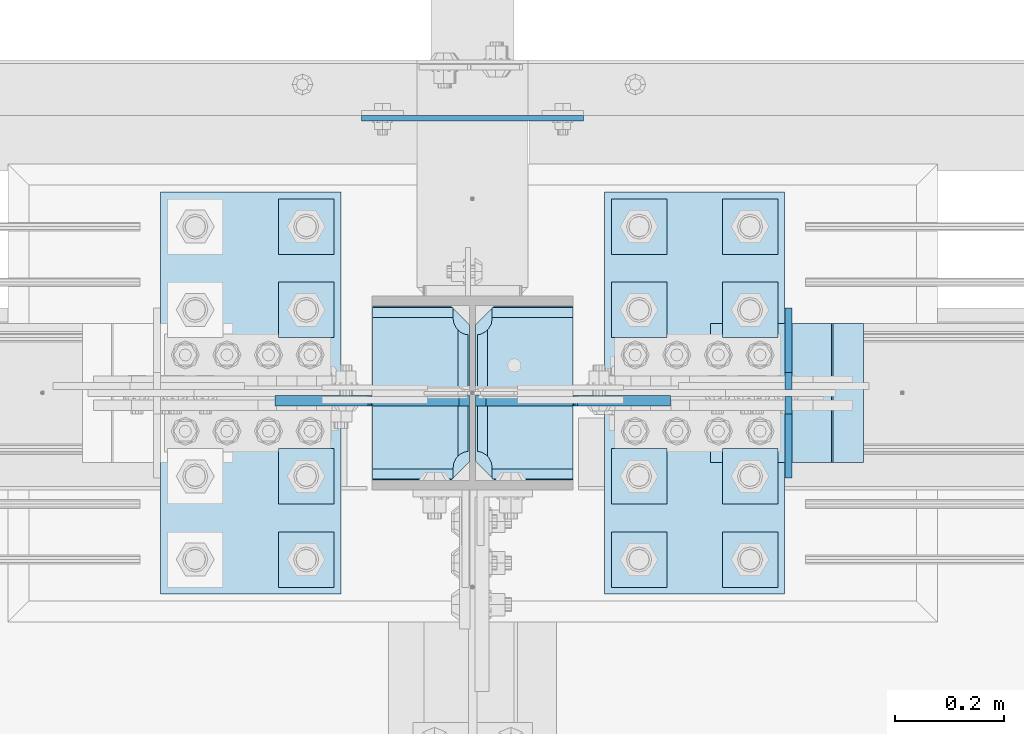
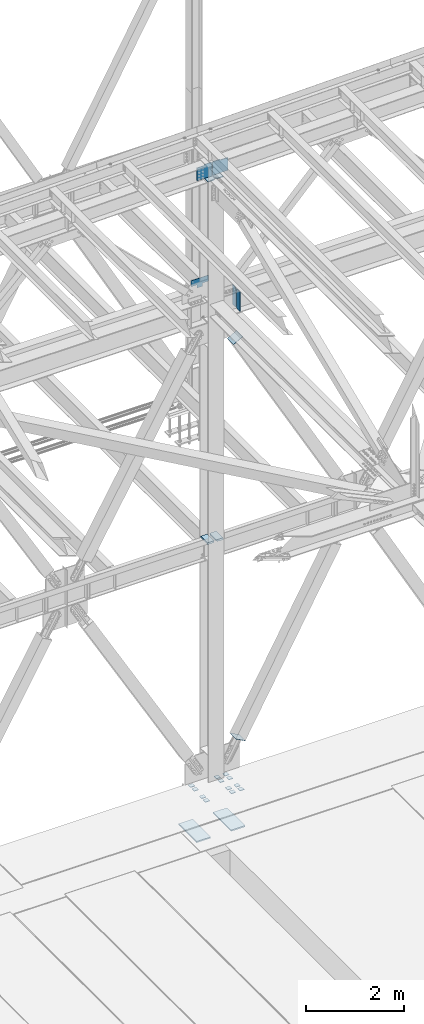
# One storey, part 3478 of 3843: 25 plates, 5 elements without a shape of their own.
"""IFC2X3 building model written with IfcOpenShell, lengths in millimetres."""

from ifc_helpers import new_model, si_unit, frame, origin_with_axes, place, context, subcontext, project, spatial, faceted_brep, material, type_object, element, aggregate, save


model = new_model("IFC2X3")

# Units and contexts
model_context = context("Model", 3, precision=1e-05, world=origin_with_axes())
body_context = subcontext(model_context, "Body", "Model", "MODEL_VIEW")
ifc_project = project(units=[si_unit("LENGTHUNIT", "METRE", prefix="MILLI"), si_unit("AREAUNIT", "SQUARE_METRE"), si_unit("VOLUMEUNIT", "CUBIC_METRE"), si_unit("MASSUNIT", "GRAM", prefix="KILO"), si_unit("TIMEUNIT", "SECOND"), si_unit("PLANEANGLEUNIT", "RADIAN"), si_unit("SOLIDANGLEUNIT", "STERADIAN"), si_unit("THERMODYNAMICTEMPERATUREUNIT", "DEGREE_CELSIUS"), si_unit("LUMINOUSINTENSITYUNIT", "LUMEN")], contexts=[model_context])

# Site, building, storey
site_placement = place(None, origin_with_axes())
site = spatial("IfcSite", under=ifc_project, at=site_placement, CompositionType="ELEMENT")
building_placement = place(site_placement, origin_with_axes())
building = spatial("IfcBuilding", under=site, at=building_placement, Name="Undefined", CompositionType="ELEMENT")
storey_placement = place(building_placement, origin_with_axes())
storey = spatial("IfcBuildingStorey", under=building, at=storey_placement, Name="Undefined", CompositionType="ELEMENT", Elevation=0.0)

# Assembly, plates
assembly_1_placement = place(storey_placement, origin_with_axes())
assembly_1 = element("IfcElementAssembly", 1, at=assembly_1_placement, inside=storey, Name="COLUMN", AssemblyPlace="NOTDEFINED", PredefinedType="RIGID_FRAME")
ifc_material_1 = material(Name="STEEL/A572-50")
plate_type_1 = type_object("IfcPlateType", PredefinedType="NOTDEFINED")
plate_1_placement = place(assembly_1_placement, frame((56114.15625, 92054.3625, 36420.425), z_axis=(0.0, 1.0, 0.0), x_axis=(-1.0, 0.0, 0.0)))
plate_1 = element("IfcPlate", 2, at=plate_1_placement, type_object=plate_type_1, material=ifc_material_1, Name="PLATE", context=body_context, shape_type="Brep", body=[
    faceted_brep([(160.070927103505, 9.33329077896633, 48.2144734940957), (156.294129000915, 15.875, 44.437675391513), (156.294129000915, 15.875, 276.23732460849), (160.070927103505, 9.33329077896633, 272.460526505907), (168.479274789282, -5.23062396988826, 268.176259371801), (174.625000047687, -15.875, 267.202872116366), (174.625000047687, -15.875, 53.4721278836369), (168.479274789282, -5.23062396988826, 52.4987406282016), (147.63749961853, 15.875, 21.5053709990898), (147.63749961853, -15.875, 3.17449995232164), (0.0, -15.875, 3.17449995232164), (0.0, 15.875, 21.5053709990898), (0.0, 15.875, 299.168629000924), (0.0, -15.875, 317.499500047692), (147.63749961853, -15.875, 317.499500047692), (147.63749961853, 15.875, 299.168629000924), (147.63749961853, -15.875, 296.862501907352), (147.63749961853, 15.875, 296.862501907352), (149.113757464445, -15.875, 287.541776696642), (149.113757464445, 15.875, 287.541776696642), (153.398024598548, -15.875, 279.133429010864), (153.398024598548, 15.875, 279.133429010864), (160.070927103505, -15.875, 272.460526505907), (168.479274789282, -15.875, 268.176259371801), (168.479274789282, -15.875, 52.4987406282016), (160.070927103505, -15.875, 48.2144734940957), (153.398024598548, -15.875, 41.5415709891386), (153.398024598548, 15.875, 41.5415709891386), (149.113757464449, -15.875, 33.1332233033609), (149.113757464449, 15.875, 33.1332233033609), (147.63749961853, -15.875, 23.8124980926514), (147.63749961853, 15.875, 23.8124980926514)], [[[0, 1, 2, 3, 4, 5, 6, 7]], [[8, 9, 10, 11]], [[12, 13, 14, 15]], [[13, 12, 11, 10]], [[16, 17, 15, 14]], [[16, 18, 19, 17]], [[18, 20, 21, 19]], [[21, 20, 22, 3, 2]], [[22, 23, 4, 3]], [[23, 5, 4]], [[24, 7, 6]], [[24, 25, 0, 7]], [[25, 26, 27, 1, 0]], [[26, 28, 29, 27]], [[28, 30, 31, 29]], [[31, 30, 9, 8]], [[27, 29, 31, 8, 11, 12, 15, 17, 19, 21, 2, 1]], [[9, 30, 28, 26, 25, 24, 6, 5, 23, 22, 20, 18, 16, 14, 13, 10]]]),
])
plate_2_placement = place(assembly_1_placement, frame((55747.44375, 92375.0375, 36420.425), z_axis=(0.0, -1.0, 0.0), x_axis=(1.0, 0.0, 0.0)))
plate_2 = element("IfcPlate", 3, at=plate_2_placement, type_object=plate_type_1, material=ifc_material_1, Name="PLATE", context=body_context, shape_type="Brep", body=[
    faceted_brep([(160.070927103505, 9.33329077896633, 48.2144734940957), (156.294129000915, 15.875, 44.437675391513), (156.294129000915, 15.875, 276.23732460849), (160.070927103505, 9.33329077896633, 272.460526505907), (168.479274789282, -5.23062396988826, 268.176259371801), (174.625000047687, -15.875, 267.202872116366), (174.625000047687, -15.875, 53.4721278836369), (168.479274789282, -5.23062396988826, 52.4987406282016), (147.63749961853, 15.875, 21.5053709990898), (147.63749961853, -15.875, 3.17449995232164), (0.0, -15.875, 3.17449995232164), (0.0, 15.875, 21.5053709990898), (0.0, 15.875, 299.168629000924), (0.0, -15.875, 317.499500047692), (147.63749961853, -15.875, 317.499500047692), (147.63749961853, 15.875, 299.168629000924), (147.63749961853, -15.875, 296.862501907352), (147.63749961853, 15.875, 296.862501907352), (149.113757464445, -15.875, 287.541776696642), (149.113757464445, 15.875, 287.541776696642), (153.398024598548, -15.875, 279.133429010864), (153.398024598548, 15.875, 279.133429010864), (160.070927103505, -15.875, 272.460526505907), (168.479274789282, -15.875, 268.176259371801), (168.479274789282, -15.875, 52.4987406282016), (160.070927103505, -15.875, 48.2144734940957), (153.398024598548, -15.875, 41.5415709891386), (153.398024598548, 15.875, 41.5415709891386), (149.113757464449, -15.875, 33.1332233033609), (149.113757464449, 15.875, 33.1332233033609), (147.63749961853, -15.875, 23.8124980926514), (147.63749961853, 15.875, 23.8124980926514)], [[[0, 1, 2, 3, 4, 5, 6, 7]], [[8, 9, 10, 11]], [[12, 13, 14, 15]], [[13, 12, 11, 10]], [[16, 17, 15, 14]], [[16, 18, 19, 17]], [[18, 20, 21, 19]], [[21, 20, 22, 3, 2]], [[22, 23, 4, 3]], [[23, 5, 4]], [[24, 7, 6]], [[24, 25, 0, 7]], [[25, 26, 27, 1, 0]], [[26, 28, 29, 27]], [[28, 30, 31, 29]], [[31, 30, 9, 8]], [[27, 29, 31, 8, 11, 12, 15, 17, 19, 21, 2, 1]], [[9, 30, 28, 26, 25, 24, 6, 5, 23, 22, 20, 18, 16, 14, 13, 10]]]),
])
plate_type_2 = type_object("IfcPlateType", PredefinedType="NOTDEFINED")
plate_3_placement = place(assembly_1_placement, frame((56114.15625, 92055.95, 45462.0453960539), z_axis=(0.0, 1.0, 0.0), x_axis=(-1.0, 0.0, 0.0)))
plate_3 = element("IfcPlate", 4, at=plate_3_placement, type_object=plate_type_2, material=ifc_material_1, Name="PLATE", context=body_context, shape_type="Brep", body=[
    faceted_brep([(0.0, -9.52500000000146, 0.0), (0.0, -9.52500000000146, 317.5), (0.0, 9.52500000000146, 317.5), (0.0, 9.52500000000146, 0.0), (144.462501525879, -9.52500000000146, 317.5), (144.462501525879, 9.52500000000146, 317.5), (177.800003051758, -9.52500000000146, 284.162498474121), (177.800003051758, 9.52500000000146, 284.162498474121), (177.800003051758, -9.52500000000146, 33.3375015258789), (177.800003051758, 9.52500000000146, 33.3375015258789), (144.462501525879, -9.52500000000146, 0.0), (144.462501525879, 9.52500000000146, 0.0)], [[[0, 1, 2, 3]], [[1, 4, 5, 2]], [[4, 6, 7, 5]], [[6, 8, 9, 7]], [[8, 10, 11, 9]], [[10, 0, 3, 11]], [[5, 7, 9, 11, 3, 2]], [[10, 8, 6, 4, 1, 0]]]),
])
plate_4_placement = place(assembly_1_placement, frame((55747.4437499977, 92373.45, 45450.540948498), z_axis=(0.0, -1.0, 0.0), x_axis=(1.0, 0.0, 0.0)))
plate_4 = element("IfcPlate", 5, at=plate_4_placement, type_object=plate_type_2, material=ifc_material_1, Name="PLATE", context=body_context, shape_type="Brep", body=[
    faceted_brep([(0.0, -9.52500000000146, 0.0), (0.0, -9.52500000000146, 317.5), (0.0, 9.52500000000146, 317.5), (0.0, 9.52500000000146, 0.0), (144.462501525879, -9.52500000000146, 317.5), (144.462501525879, 9.52500000000146, 317.5), (177.800003051758, -9.52500000000146, 284.162498474121), (177.800003051758, 9.52500000000146, 284.162498474121), (177.800003051758, -9.52500000000146, 33.3375015258789), (177.800003051758, 9.52500000000146, 33.3375015258789), (144.462501525879, -9.52500000000146, 0.0), (144.462501525879, 9.52500000000146, 0.0)], [[[0, 1, 2, 3]], [[1, 4, 5, 2]], [[4, 6, 7, 5]], [[6, 8, 9, 7]], [[8, 10, 11, 9]], [[10, 0, 3, 11]], [[5, 7, 9, 11, 3, 2]], [[10, 8, 6, 4, 1, 0]]]),
])
plate_type_3 = type_object("IfcPlateType", PredefinedType="NOTDEFINED")
plate_5_placement = place(assembly_1_placement, frame((55867.3, 92717.9375, 42367.2), z_axis=(0.0, 0.0, 1.0), x_axis=(1.0, 0.0, 0.0)))
plate_5 = element("IfcPlate", 6, at=plate_5_placement, type_object=plate_type_3, material=ifc_material_1, Name="PLATE", context=body_context, shape_type="Brep", body=[
    faceted_brep([(0.0, -4.76249999999709, 0.0), (-3.49245965480804e-10, -4.76249999999709, 76.1999999999462), (-3.49245965480804e-10, 4.76249999999709, 76.1999999999462), (0.0, 4.76249999999709, 0.0), (-139.699996948242, -4.76249999999709, 76.1999969482422), (-139.699996948242, 4.76249999999709, 76.1999969482422), (-139.699996948242, -4.76249999999709, 228.600006103516), (-139.699996948242, 4.76249999999709, 228.600006103516), (266.700012207031, -4.76249999999709, 228.600006103516), (266.700012207031, 4.76249999999709, 228.600006103516), (266.700012207031, -4.76249999999709, 76.1999969482422), (266.700012207031, 4.76249999999709, 76.1999969482422), (126.999992370605, -4.76249999999709, 76.1999969482422), (126.999992370605, 4.76249999999709, 76.1999969482422), (126.999992370605, -4.76249999999709, 0.0), (126.999992370605, 4.76249999999709, 0.0)], [[[0, 1, 2, 3]], [[1, 4, 5, 2]], [[4, 6, 7, 5]], [[6, 8, 9, 7]], [[8, 10, 11, 9]], [[10, 12, 13, 11]], [[12, 14, 15, 13]], [[14, 0, 3, 15]], [[5, 7, 9, 11, 13, 15, 3, 2]], [[14, 12, 10, 8, 6, 4, 1, 0]]]),
])

assembly_2_placement = place(storey_placement, origin_with_axes())
assembly_2 = element("IfcElementAssembly", 7, at=assembly_2_placement, inside=storey, Name="BEAM", AssemblyPlace="NOTDEFINED", PredefinedType="RIGID_FRAME")
plate_type_4 = type_object("IfcPlateType", PredefinedType="NOTDEFINED")
plate_6_placement = place(assembly_2_placement, frame((56509.4345205975, 92221.05, 41948.1), z_axis=(0.0, 1.0, 0.0), x_axis=(0.0, 0.0, 1.0)))
plate_6 = element("IfcPlate", 8, at=plate_6_placement, type_object=plate_type_4, material=ifc_material_1, Name="CB_BEAM", context=body_context, shape_type="Brep", body=[
    faceted_brep([(0.0, -6.35000000000582, 31.75), (0.0, -6.34999999999854, 149.225000000006), (0.0, 6.34999999999854, 149.225000000006), (0.0, 6.35000000000582, 31.75), (498.474999999991, -6.34999999999854, 149.225000000006), (498.474999999991, 6.34999999999854, 149.225000000006), (498.474999999991, -6.34999999999854, 31.75), (498.474999999991, 6.34999999999854, 31.75), (466.724999999991, -6.34999999999854, 0.0), (466.724999999991, 6.34999999999854, 0.0), (31.75, -6.35000000000582, 0.0), (31.75, 6.35000000000582, 0.0)], [[[0, 1, 2, 3]], [[1, 4, 5, 2]], [[4, 6, 7, 5]], [[6, 8, 9, 7]], [[8, 10, 11, 9]], [[10, 0, 3, 11]], [[5, 7, 9, 11, 3, 2]], [[10, 8, 6, 4, 1, 0]]]),
])
plate_7_placement = place(assembly_2_placement, frame((56509.4345205975, 92208.35, 41948.1), z_axis=(0.0, -1.0, 0.0), x_axis=(0.0, 0.0, 1.0)))
plate_7 = element("IfcPlate", 9, at=plate_7_placement, type_object=plate_type_4, material=ifc_material_1, Name="CB_BEAM", context=body_context, shape_type="Brep", body=[
    faceted_brep([(0.0, -6.35000000000582, 31.75), (0.0, -6.34999999999854, 149.225000000006), (0.0, 6.34999999999854, 149.225000000006), (0.0, 6.35000000000582, 31.75), (498.474999999991, -6.34999999999854, 149.225000000006), (498.474999999991, 6.34999999999854, 149.225000000006), (498.474999999991, -6.34999999999854, 31.75), (498.474999999991, 6.34999999999854, 31.75), (466.724999999991, -6.34999999999854, 0.0), (466.724999999991, 6.34999999999854, 0.0), (31.75, -6.35000000000582, 0.0), (31.75, 6.35000000000582, 0.0)], [[[0, 1, 2, 3]], [[1, 4, 5, 2]], [[4, 6, 7, 5]], [[6, 8, 9, 7]], [[8, 10, 11, 9]], [[10, 0, 3, 11]], [[5, 7, 9, 11, 3, 2]], [[10, 8, 6, 4, 1, 0]]]),
])
aggregate(assembly_2, [plate_6, plate_7])

assembly_3_placement = place(storey_placement, origin_with_axes())
assembly_3 = element("IfcElementAssembly", 10, at=assembly_3_placement, inside=storey, Name="TEMPLATE", AssemblyPlace="NOTDEFINED", PredefinedType="RIGID_FRAME")
plate_type_5 = type_object("IfcPlateType", PredefinedType="NOTDEFINED")
plate_8_placement = place(assembly_3_placement, frame((55676.8, 91960.7, 30156.15), z_axis=(-1.0, 0.0, 0.0), x_axis=(0.0, -1.0, 0.0)))
plate_8 = element("IfcPlate", 11, at=plate_8_placement, type_object=plate_type_5, material=ifc_material_1, Name="Washer Plate", context=body_context, shape_type="Brep", body=[
    faceted_brep([(0.0, -6.3499999046162, 0.0), (-1.67347025126219e-10, -6.35000000000582, 101.600000000151), (-1.67347025126219e-10, 6.35000000000582, 101.600000000151), (7.27595761418343e-12, 6.3499999046162, 0.0), (101.599998474121, -6.34999999999854, 101.599998474121), (101.599998474121, 6.34999999999854, 101.599998474121), (101.6, -6.34999999999854, 0.0), (101.6, 6.34999999999854, 0.0)], [[[0, 1, 2, 3]], [[1, 4, 5, 2]], [[4, 6, 7, 5]], [[6, 0, 3, 7]], [[5, 7, 3, 2]], [[6, 4, 1, 0]]]),
])
plate_9_placement = place(assembly_3_placement, frame((56286.4, 91960.7, 30156.15), z_axis=(-1.0, 0.0, 0.0), x_axis=(0.0, -1.0, 0.0)))
plate_9 = element("IfcPlate", 12, at=plate_9_placement, type_object=plate_type_5, material=ifc_material_1, Name="Washer Plate", context=body_context, shape_type="Brep", body=[
    faceted_brep([(0.0, -6.3499999046162, 0.0), (-1.67347025126219e-10, -6.35000000000582, 101.600000000151), (-1.67347025126219e-10, 6.35000000000582, 101.600000000151), (7.27595761418343e-12, 6.3499999046162, 0.0), (101.599998474121, -6.34999999999854, 101.599998474121), (101.599998474121, 6.34999999999854, 101.599998474121), (101.6, -6.34999999999854, 0.0), (101.6, 6.34999999999854, 0.0)], [[[0, 1, 2, 3]], [[1, 4, 5, 2]], [[4, 6, 7, 5]], [[6, 0, 3, 7]], [[5, 7, 3, 2]], [[6, 4, 1, 0]]]),
])
plate_10_placement = place(assembly_3_placement, frame((56489.6, 91960.7, 30156.15), z_axis=(-1.0, 0.0, 0.0), x_axis=(0.0, -1.0, 0.0)))
plate_10 = element("IfcPlate", 13, at=plate_10_placement, type_object=plate_type_5, material=ifc_material_1, Name="Washer Plate", context=body_context, shape_type="Brep", body=[
    faceted_brep([(0.0, -6.3499999046162, 0.0), (-1.67347025126219e-10, -6.35000000000582, 101.600000000151), (-1.67347025126219e-10, 6.35000000000582, 101.600000000151), (7.27595761418343e-12, 6.3499999046162, 0.0), (101.599998474121, -6.34999999999854, 101.599998474121), (101.599998474121, 6.34999999999854, 101.599998474121), (101.6, -6.34999999999854, 0.0), (101.6, 6.34999999999854, 0.0)], [[[0, 1, 2, 3]], [[1, 4, 5, 2]], [[4, 6, 7, 5]], [[6, 0, 3, 7]], [[5, 7, 3, 2]], [[6, 4, 1, 0]]]),
])
plate_11_placement = place(assembly_3_placement, frame((55676.8, 92113.1, 30156.15), z_axis=(-1.0, 0.0, 0.0), x_axis=(0.0, -1.0, 0.0)))
plate_11 = element("IfcPlate", 14, at=plate_11_placement, type_object=plate_type_5, material=ifc_material_1, Name="Washer Plate", context=body_context, shape_type="Brep", body=[
    faceted_brep([(0.0, -6.3499999046162, 0.0), (-1.67347025126219e-10, -6.35000000000582, 101.600000000151), (-1.67347025126219e-10, 6.35000000000582, 101.600000000151), (7.27595761418343e-12, 6.3499999046162, 0.0), (101.599998474121, -6.34999999999854, 101.599998474121), (101.599998474121, 6.34999999999854, 101.599998474121), (101.6, -6.34999999999854, 0.0), (101.6, 6.34999999999854, 0.0)], [[[0, 1, 2, 3]], [[1, 4, 5, 2]], [[4, 6, 7, 5]], [[6, 0, 3, 7]], [[5, 7, 3, 2]], [[6, 4, 1, 0]]]),
])
plate_12_placement = place(assembly_3_placement, frame((56286.4, 92113.1, 30156.15), z_axis=(-1.0, 0.0, 0.0), x_axis=(0.0, -1.0, 0.0)))
plate_12 = element("IfcPlate", 15, at=plate_12_placement, type_object=plate_type_5, material=ifc_material_1, Name="Washer Plate", context=body_context, shape_type="Brep", body=[
    faceted_brep([(0.0, -6.3499999046162, 0.0), (-1.67347025126219e-10, -6.35000000000582, 101.600000000151), (-1.67347025126219e-10, 6.35000000000582, 101.600000000151), (7.27595761418343e-12, 6.3499999046162, 0.0), (101.599998474121, -6.34999999999854, 101.599998474121), (101.599998474121, 6.34999999999854, 101.599998474121), (101.6, -6.34999999999854, 0.0), (101.6, 6.34999999999854, 0.0)], [[[0, 1, 2, 3]], [[1, 4, 5, 2]], [[4, 6, 7, 5]], [[6, 0, 3, 7]], [[5, 7, 3, 2]], [[6, 4, 1, 0]]]),
])
plate_13_placement = place(assembly_3_placement, frame((56489.6, 92113.1, 30156.15), z_axis=(-1.0, 0.0, 0.0), x_axis=(0.0, -1.0, 0.0)))
plate_13 = element("IfcPlate", 16, at=plate_13_placement, type_object=plate_type_5, material=ifc_material_1, Name="Washer Plate", context=body_context, shape_type="Brep", body=[
    faceted_brep([(0.0, -6.3499999046162, 0.0), (-1.67347025126219e-10, -6.35000000000582, 101.600000000151), (-1.67347025126219e-10, 6.35000000000582, 101.600000000151), (7.27595761418343e-12, 6.3499999046162, 0.0), (101.599998474121, -6.34999999999854, 101.599998474121), (101.599998474121, 6.34999999999854, 101.599998474121), (101.6, -6.34999999999854, 0.0), (101.6, 6.34999999999854, 0.0)], [[[0, 1, 2, 3]], [[1, 4, 5, 2]], [[4, 6, 7, 5]], [[6, 0, 3, 7]], [[5, 7, 3, 2]], [[6, 4, 1, 0]]]),
])
plate_14_placement = place(assembly_3_placement, frame((55676.8, 92417.9, 30156.15), z_axis=(-1.0, 0.0, 0.0), x_axis=(0.0, -1.0, 0.0)))
plate_14 = element("IfcPlate", 17, at=plate_14_placement, type_object=plate_type_5, material=ifc_material_1, Name="Washer Plate", context=body_context, shape_type="Brep", body=[
    faceted_brep([(0.0, -6.3499999046162, 0.0), (-1.67347025126219e-10, -6.35000000000582, 101.600000000151), (-1.67347025126219e-10, 6.35000000000582, 101.600000000151), (7.27595761418343e-12, 6.3499999046162, 0.0), (101.599998474121, -6.34999999999854, 101.599998474121), (101.599998474121, 6.34999999999854, 101.599998474121), (101.6, -6.34999999999854, 0.0), (101.6, 6.34999999999854, 0.0)], [[[0, 1, 2, 3]], [[1, 4, 5, 2]], [[4, 6, 7, 5]], [[6, 0, 3, 7]], [[5, 7, 3, 2]], [[6, 4, 1, 0]]]),
])
plate_15_placement = place(assembly_3_placement, frame((56286.4, 92417.9, 30156.15), z_axis=(-1.0, 0.0, 0.0), x_axis=(0.0, -1.0, 0.0)))
plate_15 = element("IfcPlate", 18, at=plate_15_placement, type_object=plate_type_5, material=ifc_material_1, Name="Washer Plate", context=body_context, shape_type="Brep", body=[
    faceted_brep([(0.0, -6.3499999046162, 0.0), (-1.67347025126219e-10, -6.35000000000582, 101.600000000151), (-1.67347025126219e-10, 6.35000000000582, 101.600000000151), (7.27595761418343e-12, 6.3499999046162, 0.0), (101.599998474121, -6.34999999999854, 101.599998474121), (101.599998474121, 6.34999999999854, 101.599998474121), (101.6, -6.34999999999854, 0.0), (101.6, 6.34999999999854, 0.0)], [[[0, 1, 2, 3]], [[1, 4, 5, 2]], [[4, 6, 7, 5]], [[6, 0, 3, 7]], [[5, 7, 3, 2]], [[6, 4, 1, 0]]]),
])
plate_16_placement = place(assembly_3_placement, frame((56489.6, 92417.9, 30156.15), z_axis=(-1.0, 0.0, 0.0), x_axis=(0.0, -1.0, 0.0)))
plate_16 = element("IfcPlate", 19, at=plate_16_placement, type_object=plate_type_5, material=ifc_material_1, Name="Washer Plate", context=body_context, shape_type="Brep", body=[
    faceted_brep([(0.0, -6.3499999046162, 0.0), (-1.67347025126219e-10, -6.35000000000582, 101.600000000151), (-1.67347025126219e-10, 6.35000000000582, 101.600000000151), (7.27595761418343e-12, 6.3499999046162, 0.0), (101.599998474121, -6.34999999999854, 101.599998474121), (101.599998474121, 6.34999999999854, 101.599998474121), (101.6, -6.34999999999854, 0.0), (101.6, 6.34999999999854, 0.0)], [[[0, 1, 2, 3]], [[1, 4, 5, 2]], [[4, 6, 7, 5]], [[6, 0, 3, 7]], [[5, 7, 3, 2]], [[6, 4, 1, 0]]]),
])
plate_17_placement = place(assembly_3_placement, frame((55676.8, 92570.3, 30156.15), z_axis=(-1.0, 0.0, 0.0), x_axis=(0.0, -1.0, 0.0)))
plate_17 = element("IfcPlate", 20, at=plate_17_placement, type_object=plate_type_5, material=ifc_material_1, Name="Washer Plate", context=body_context, shape_type="Brep", body=[
    faceted_brep([(0.0, -6.3499999046162, 0.0), (-1.67347025126219e-10, -6.35000000000582, 101.600000000151), (-1.67347025126219e-10, 6.35000000000582, 101.600000000151), (7.27595761418343e-12, 6.3499999046162, 0.0), (101.599998474121, -6.34999999999854, 101.599998474121), (101.599998474121, 6.34999999999854, 101.599998474121), (101.6, -6.34999999999854, 0.0), (101.6, 6.34999999999854, 0.0)], [[[0, 1, 2, 3]], [[1, 4, 5, 2]], [[4, 6, 7, 5]], [[6, 0, 3, 7]], [[5, 7, 3, 2]], [[6, 4, 1, 0]]]),
])
plate_18_placement = place(assembly_3_placement, frame((56286.4, 92570.3, 30156.15), z_axis=(-1.0, 0.0, 0.0), x_axis=(0.0, -1.0, 0.0)))
plate_18 = element("IfcPlate", 21, at=plate_18_placement, type_object=plate_type_5, material=ifc_material_1, Name="Washer Plate", context=body_context, shape_type="Brep", body=[
    faceted_brep([(0.0, -6.3499999046162, 0.0), (-1.67347025126219e-10, -6.35000000000582, 101.600000000151), (-1.67347025126219e-10, 6.35000000000582, 101.600000000151), (7.27595761418343e-12, 6.3499999046162, 0.0), (101.599998474121, -6.34999999999854, 101.599998474121), (101.599998474121, 6.34999999999854, 101.599998474121), (101.6, -6.34999999999854, 0.0), (101.6, 6.34999999999854, 0.0)], [[[0, 1, 2, 3]], [[1, 4, 5, 2]], [[4, 6, 7, 5]], [[6, 0, 3, 7]], [[5, 7, 3, 2]], [[6, 4, 1, 0]]]),
])
plate_19_placement = place(assembly_3_placement, frame((56489.6, 92570.3, 30156.15), z_axis=(-1.0, 0.0, 0.0), x_axis=(0.0, -1.0, 0.0)))
plate_19 = element("IfcPlate", 22, at=plate_19_placement, type_object=plate_type_5, material=ifc_material_1, Name="Washer Plate", context=body_context, shape_type="Brep", body=[
    faceted_brep([(0.0, -6.3499999046162, 0.0), (-1.67347025126219e-10, -6.35000000000582, 101.600000000151), (-1.67347025126219e-10, 6.35000000000582, 101.600000000151), (7.27595761418343e-12, 6.3499999046162, 0.0), (101.599998474121, -6.34999999999854, 101.599998474121), (101.599998474121, 6.34999999999854, 101.599998474121), (101.6, -6.34999999999854, 0.0), (101.6, 6.34999999999854, 0.0)], [[[0, 1, 2, 3]], [[1, 4, 5, 2]], [[4, 6, 7, 5]], [[6, 0, 3, 7]], [[5, 7, 3, 2]], [[6, 4, 1, 0]]]),
])

# Assembly, plate
assembly_4_placement = place(storey_placement, origin_with_axes())
assembly_4 = element("IfcElementAssembly", 23, at=assembly_4_placement, inside=storey, Name="Plate", AssemblyPlace="NOTDEFINED", PredefinedType="RIGID_FRAME")
ifc_material_2 = material(Name="STEEL/A36")
plate_type_6 = type_object("IfcPlateType", PredefinedType="NOTDEFINED")
plate_20_placement = place(assembly_4_placement, frame((56367.6921914295, 92341.7, 41156.5973769065), z_axis=(0.872780312308932, 0.0, 0.488113231172771), x_axis=(0.0, -1.0, 0.0)))
plate_20 = element("IfcPlate", 24, at=plate_20_placement, type_object=plate_type_6, material=ifc_material_2, Name="Plate", context=body_context, shape_type="Brep", body=[
    faceted_brep([(0.0, -3.17499999999927, 0.0), (0.0, -3.17499999965185, 254.000000005151), (0.0, 3.17500000035216, 254.000000005166), (0.0, 3.17499999999927, 0.0), (254.0, -3.17499999965185, 254.000000005151), (254.0, 3.17500000035216, 254.000000005166), (254.0, -3.17500000000291, 0.0), (254.0, 3.17499999999927, 1.45519152283669e-11)], [[[0, 1, 2, 3]], [[1, 4, 5, 2]], [[4, 6, 7, 5]], [[6, 0, 3, 7]], [[5, 7, 3, 2]], [[6, 4, 1, 0]]]),
])
aggregate(assembly_4, [plate_20])

assembly_5_placement = place(storey_placement, origin_with_axes())
assembly_5 = element("IfcElementAssembly", 25, at=assembly_5_placement, inside=storey, Name="Plate", AssemblyPlace="NOTDEFINED", PredefinedType="RIGID_FRAME")
plate_21_placement = place(assembly_5_placement, frame((56644.9450482298, 92087.7, 31177.0073841618), z_axis=(-0.874773404023983, 0.0, 0.484532240013287), x_axis=(0.0, 1.0, 0.0)))
plate_21 = element("IfcPlate", 26, at=plate_21_placement, type_object=plate_type_6, material=ifc_material_2, Name="Plate", context=body_context, shape_type="Brep", body=[
    faceted_brep([(0.0, -3.17499999999927, 0.0), (0.0, -3.17499999965185, 254.000000005151), (0.0, 3.17500000035216, 254.000000005166), (0.0, 3.17499999999927, 0.0), (254.0, -3.17499999965185, 254.000000005151), (254.0, 3.17500000035216, 254.000000005166), (254.0, -3.17500000000291, 0.0), (254.0, 3.17499999999927, 1.45519152283669e-11)], [[[0, 1, 2, 3]], [[1, 4, 5, 2]], [[4, 6, 7, 5]], [[6, 0, 3, 7]], [[5, 7, 3, 2]], [[6, 4, 1, 0]]]),
])
aggregate(assembly_5, [plate_21])

# Plate
plate_type_7 = type_object("IfcPlateType", PredefinedType="NOTDEFINED")
plate_22_placement = place(assembly_1_placement, frame((55936.35625, 92200.4124996185, 45490.6203960282), z_axis=(0.707106781186548, 0.0, 0.707106781186548), x_axis=(0.707106781186548, 0.0, -0.707106781186548)))
plate_22 = element("IfcPlate", 27, at=plate_22_placement, type_object=plate_type_7, material=ifc_material_1, Name="PLATE", context=body_context, shape_type="Brep", body=[
    faceted_brep([(0.0, -9.52500000000146, 0.0), (-209.979301496754, -9.52500000000146, 209.979301496671), (-209.979301496754, 9.52500000000146, 209.979301496671), (0.0, 9.52500000000146, 0.0), (-209.979301496471, -9.52500000000146, 236.920069860033), (-209.979301496471, 9.52500000000146, 236.920069860033), (-97.1648339737767, -9.52500000000146, 349.734537382756), (-97.1648339737767, 9.52500000000146, 349.734537382756), (-93.3396839560301, -9.52500000000146, 345.909387365013), (-93.3396839560301, 9.52500000000146, 345.909387365013), (-89.219507487891, -9.52500000000146, 343.156373464546), (-89.219507487891, 9.52500000000146, 343.156373464546), (-84.35942796983, -9.52500000000146, 342.189643541991), (-84.35942796983, 9.52500000000146, 342.189643541991), (-79.4993484517727, -9.52500000000146, 343.15637346459), (-79.4993484517727, 9.52500000000146, 343.15637346459), (-75.3791719835863, -9.52500000000146, 345.909387365115), (-75.3791719835863, 9.52500000000146, 345.909387365115), (41.3641577270682, -9.52500000000146, 462.652717075805), (41.3641577270682, 9.52500000000146, 462.652717075805), (265.870560752759, -9.52500000000146, 238.146314050202), (265.870560752759, 9.52500000000146, 238.146314050202), (26.9407683632344, -9.52499999999964, 2.03726813197136e-10), (26.9407683632344, 9.52499999999964, 2.03726813197136e-10)], [[[0, 1, 2, 3]], [[1, 4, 5, 2]], [[4, 6, 7, 5]], [[6, 8, 9, 7]], [[8, 10, 11, 9]], [[10, 12, 13, 11]], [[12, 14, 15, 13]], [[14, 16, 17, 15]], [[16, 18, 19, 17]], [[18, 20, 21, 19]], [[20, 22, 23, 21]], [[22, 0, 3, 23]], [[5, 7, 9, 11, 13, 15, 17, 19, 21, 23, 3, 2]], [[22, 20, 18, 16, 14, 12, 10, 8, 6, 4, 1, 0]]]),
])

plate_type_8 = type_object("IfcPlateType", PredefinedType="NOTDEFINED")
plate_23_placement = place(assembly_1_placement, frame((55925.24375, 92200.4124996185, 45479.1159484022), z_axis=(-0.707106781186548, 0.0, 0.707106781186548), x_axis=(-0.707106781186548, 0.0, -0.707106781186548)))
plate_23 = element("IfcPlate", 28, at=plate_23_placement, type_object=plate_type_8, material=ifc_material_1, Name="PLATE", context=body_context, shape_type="Brep", body=[
    faceted_brep([(0.0, -9.52500000000146, 0.0), (-217.83702560261, -9.52500000000146, 217.837025602606), (-217.83702560261, 9.52500000000146, 217.837025602606), (0.0, 9.52500000000146, 0.0), (-217.837025602319, -9.52500000000146, 244.777793965968), (-217.837025602319, 9.52500000000146, 244.777793965968), (-105.02255807961, -9.52500000000146, 357.592261488677), (-105.02255807961, 9.52500000000146, 357.592261488677), (-94.254791630985, -9.52500000000146, 346.824495040062), (-94.254791630985, 9.52500000000146, 346.824495040062), (-90.1346151628532, -9.52500000000146, 344.071481139596), (-90.1346151628532, 9.52500000000146, 344.071481139596), (-85.2745356447995, -9.52500000000146, 343.104751217026), (-85.2745356447995, 9.52500000000146, 343.104751217026), (-80.4144561267167, -9.52500000000146, 344.07148113965), (-80.4144561267167, 9.52500000000146, 344.07148113965), (-76.2942796585558, -9.52500000000146, 346.824495040149), (-76.2942796585558, 9.52500000000146, 346.824495040149), (40.4490500521206, -9.52500000000146, 463.567824750826), (40.4490500521206, 9.52500000000146, 463.567824750826), (264.955453077768, -9.52500000000146, 239.061421725179), (264.955453077768, 9.52500000000146, 239.061421725179), (26.9407683632344, -9.52499999999964, 2.03726813197136e-10), (26.9407683632344, 9.52499999999964, 2.03726813197136e-10)], [[[0, 1, 2, 3]], [[1, 4, 5, 2]], [[4, 6, 7, 5]], [[6, 8, 9, 7]], [[8, 10, 11, 9]], [[10, 12, 13, 11]], [[12, 14, 15, 13]], [[14, 16, 17, 15]], [[16, 18, 19, 17]], [[18, 20, 21, 19]], [[20, 22, 23, 21]], [[22, 0, 3, 23]], [[5, 7, 9, 11, 13, 15, 17, 19, 21, 23, 3, 2]], [[22, 20, 18, 16, 14, 12, 10, 8, 6, 4, 1, 0]]]),
])

aggregate(assembly_1, [plate_5, plate_3, plate_22, plate_4, plate_23, plate_1, plate_2])

plate_type_9 = type_object("IfcPlateType", PredefinedType="NOTDEFINED")
plate_24_placement = place(assembly_3_placement, frame((55359.3, 92583.0000030517, 29244.925), z_axis=(1.0, 0.0, 0.0), x_axis=(0.0, -1.0, 0.0)))
plate_24 = element("IfcPlate", 29, at=plate_24_placement, type_object=plate_type_9, material=ifc_material_1, Name="PLATE", context=body_context, shape_type="Brep", body=[
    faceted_brep([(0.0, -15.875, 0.0), (0.0, -15.875, 330.200012207031), (0.0, 15.875, 330.200012207031), (0.0, 15.875, 0.0), (736.600036621094, -15.875, 330.200012207031), (736.600036621094, 15.875, 330.200012207031), (736.600036621094, -15.875, 0.0), (736.600036621094, 15.875, 0.0)], [[[0, 1, 2, 3]], [[1, 4, 5, 2]], [[4, 6, 7, 5]], [[6, 0, 3, 7]], [[5, 7, 3, 2]], [[6, 4, 1, 0]]]),
])

plate_25_placement = place(assembly_3_placement, frame((56172.1, 92583.0000030517, 29244.925), z_axis=(1.0, 0.0, 0.0), x_axis=(0.0, -1.0, 0.0)))
plate_25 = element("IfcPlate", 30, at=plate_25_placement, type_object=plate_type_9, material=ifc_material_1, Name="PLATE", context=body_context, shape_type="Brep", body=[
    faceted_brep([(0.0, -15.875, 0.0), (0.0, -15.875, 330.200012207031), (0.0, 15.875, 330.200012207031), (0.0, 15.875, 0.0), (736.600036621094, -15.875, 330.200012207031), (736.600036621094, 15.875, 330.200012207031), (736.600036621094, -15.875, 0.0), (736.600036621094, 15.875, 0.0)], [[[0, 1, 2, 3]], [[1, 4, 5, 2]], [[4, 6, 7, 5]], [[6, 0, 3, 7]], [[5, 7, 3, 2]], [[6, 4, 1, 0]]]),
])

aggregate(assembly_3, [plate_24, plate_25, plate_8, plate_9, plate_10, plate_11, plate_12, plate_13, plate_14, plate_15, plate_16, plate_17, plate_18, plate_19])

save(model, "model.ifc")
